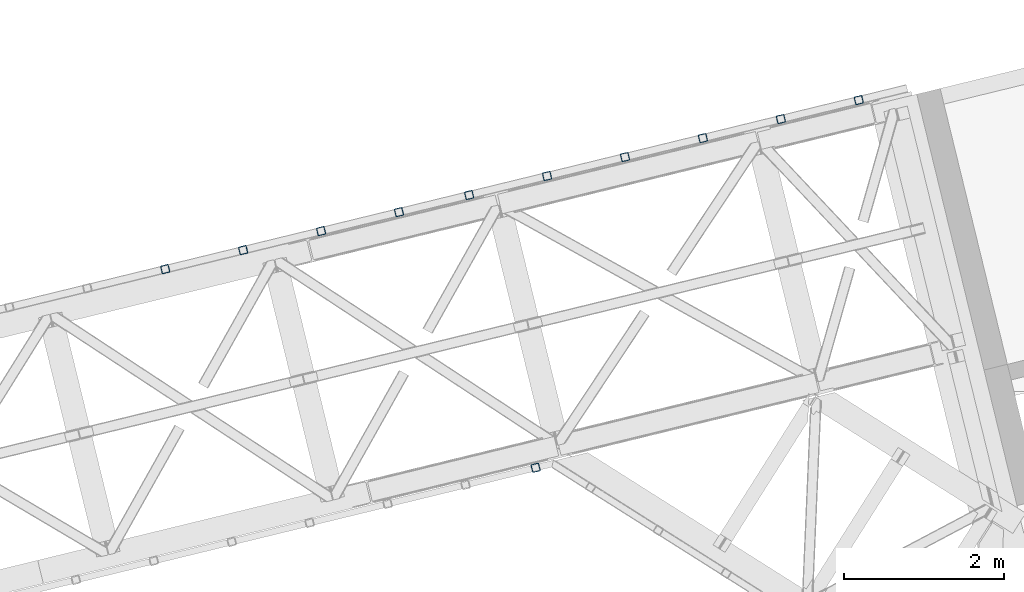
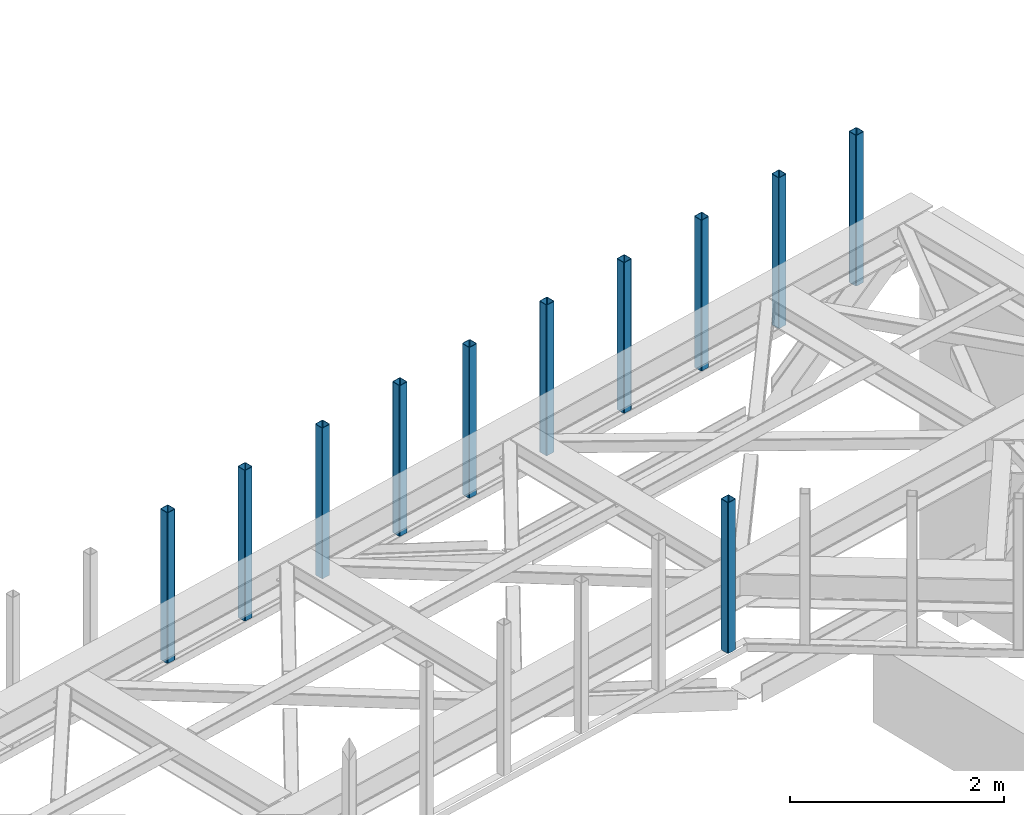
# One storey, part 11 of 66: 11 columns.
"""IFC4 building model written with IfcOpenShell, lengths in millimetres."""

from ifc_helpers import new_model, entity, si_unit, converted_unit, derived_unit, direction, frame, origin, place, context, subcontext, project, spatial, indexed_curve, outline, extrude, type_object, element, save


model = new_model("IFC4")

# Units and contexts
model_context = context("Model", 3, precision=0.01, world=origin(), true_north=direction((6.12303176911189e-17, 1.0)))
plan_context = context("Plan", 3, precision=0.01, world=origin(), true_north=direction((6.12303176911189e-17, 1.0)))
body_context = subcontext(model_context, "Body", "Model", "MODEL_VIEW")
ifc_project = project(units=[si_unit("LENGTHUNIT", "METRE", prefix="MILLI"), si_unit("AREAUNIT", "SQUARE_METRE"), si_unit("VOLUMEUNIT", "CUBIC_METRE"), converted_unit("PLANEANGLEUNIT", "DEGREE", entity("IfcRatioMeasure", 0.0174532925199433), si_unit("PLANEANGLEUNIT", "RADIAN"), dimensions=[0, 0, 0, 0, 0, 0, 0]), si_unit("MASSUNIT", "GRAM", prefix="KILO"), derived_unit("MASSDENSITYUNIT", [(si_unit("MASSUNIT", "GRAM", prefix="KILO"), 1), (si_unit("LENGTHUNIT", "METRE"), -3)]), derived_unit("MOMENTOFINERTIAUNIT", [(si_unit("LENGTHUNIT", "METRE"), 4)]), si_unit("TIMEUNIT", "SECOND"), si_unit("FREQUENCYUNIT", "HERTZ"), si_unit("THERMODYNAMICTEMPERATUREUNIT", "DEGREE_CELSIUS"), derived_unit("THERMALTRANSMITTANCEUNIT", [(si_unit("MASSUNIT", "GRAM", prefix="KILO"), 1), (si_unit("THERMODYNAMICTEMPERATUREUNIT", "KELVIN"), -1), (si_unit("TIMEUNIT", "SECOND"), -3)]), derived_unit("VOLUMETRICFLOWRATEUNIT", [(si_unit("LENGTHUNIT", "METRE"), 3), (si_unit("TIMEUNIT", "SECOND"), -1)]), derived_unit("MASSFLOWRATEUNIT", [(si_unit("MASSUNIT", "GRAM", prefix="KILO"), 1), (si_unit("TIMEUNIT", "SECOND"), -1)]), derived_unit("ROTATIONALFREQUENCYUNIT", [(si_unit("TIMEUNIT", "SECOND"), -1)]), si_unit("ELECTRICCURRENTUNIT", "AMPERE"), si_unit("ELECTRICVOLTAGEUNIT", "VOLT"), si_unit("POWERUNIT", "WATT"), si_unit("FORCEUNIT", "NEWTON", prefix="KILO"), si_unit("ILLUMINANCEUNIT", "LUX"), si_unit("LUMINOUSFLUXUNIT", "LUMEN"), si_unit("LUMINOUSINTENSITYUNIT", "CANDELA"), derived_unit("USERDEFINED", [(si_unit("MASSUNIT", "GRAM", prefix="KILO"), -1), (si_unit("LENGTHUNIT", "METRE"), -2), (si_unit("TIMEUNIT", "SECOND"), 3), (si_unit("LUMINOUSFLUXUNIT", "LUMEN"), 1)]), derived_unit("LINEARVELOCITYUNIT", [(si_unit("LENGTHUNIT", "METRE"), 1), (si_unit("TIMEUNIT", "SECOND"), -1)]), si_unit("PRESSUREUNIT", "PASCAL"), derived_unit("USERDEFINED", [(si_unit("LENGTHUNIT", "METRE"), -2), (si_unit("MASSUNIT", "GRAM", prefix="KILO"), 1), (si_unit("TIMEUNIT", "SECOND"), -2)]), derived_unit("LINEARFORCEUNIT", [(si_unit("MASSUNIT", "GRAM", prefix="KILO"), 1), (si_unit("LENGTHUNIT", "METRE"), 1), (si_unit("TIMEUNIT", "SECOND"), -2), (si_unit("LENGTHUNIT", "METRE"), -1)]), derived_unit("PLANARFORCEUNIT", [(si_unit("MASSUNIT", "GRAM", prefix="KILO"), 1), (si_unit("LENGTHUNIT", "METRE"), 1), (si_unit("TIMEUNIT", "SECOND"), -2), (si_unit("LENGTHUNIT", "METRE"), -2)])], contexts=[model_context, plan_context])

# Site, building, storey
site_placement = place(None, origin())
site = spatial("IfcSite", under=ifc_project, at=site_placement, CompositionType="ELEMENT")
building_placement = place(site_placement, origin())
building = spatial("IfcBuilding", under=site, at=building_placement, CompositionType="ELEMENT")
storey_placement = place(building_placement, frame((0.0, 0.0, 19800.0)))
storey = spatial("IfcBuildingStorey", under=building, at=storey_placement, Name="06", CompositionType="ELEMENT", Elevation=19800.0)

# Columns
column_type_1 = type_object("IfcColumnType", PredefinedType="COLUMN")
placement = place(storey_placement, origin())
element("IfcColumn", 1, at=placement, inside=storey, type_object=column_type_1, ObjectType="Steel Column", PredefinedType="COLUMN", context=body_context, shape_type="SweptSolid", body=[
    extrude(outline(indexed_curve([(29.4768951153438, -56.8428769007969), (33.3787015556646, -56.8428769007969), (36.9835006656957, -55.3497202197868), (39.742494458526, -52.5907264269608), (41.235651139533, -48.9859273169217), (56.8428769007998, 29.476895115338), (56.8428769007996, 33.3787015556615), (55.3497202197897, 36.9835006656988), (52.5907264269624, 39.7424944585244), (48.9859273169288, 41.2356511395317), (-29.476895115342, 56.8428769008008), (-33.3787015556628, 56.8428769008008), (-36.9835006657015, 55.3497202197943), (-39.7424944585166, 52.5907264269612), (-41.2356511395312, 48.9859273169256), (-56.8428769007996, -29.4768951153381), (-56.84287690079, -33.3787015556612), (-55.3497202197955, -36.9835006656913), (-52.5907264269606, -39.7424944585204), (-48.985927316927, -41.2356511395278), (29.4768951153438, -56.8428769007969)], self_intersect=False), holes=[indexed_curve([(-43.1065493048248, -37.3071763475937), (-46.7113484148532, -35.8140196665887), (-49.4703422076904, -33.0550258737586), (-50.9634988886897, -29.4502267637262), (-50.9634988886947, -25.5484203234053), (-37.3071763475804, 43.106549304824), (-35.8140196665827, 46.7113484148579), (-33.0550258737537, 49.470342207694), (-29.4502267637163, 50.9634988886964), (-25.5484203233976, 50.9634988887022), (43.1065493048361, 37.3071763475885), (46.7113484148689, 35.8140196665814), (49.4703422076964, 33.0550258737511), (50.963498888715, 29.450226763724), (50.9634988887109, 25.5484203233977), (37.3071763475966, -43.1065493048315), (35.8140196665955, -46.7113484148734), (33.0550258737621, -49.4703422076932), (29.4502267637325, -50.963498888704), (25.5484203234073, -50.9634988887019), (-43.1065493048248, -37.3071763475937)], self_intersect=False)]), frame((-1656.48, 20594.42, 3378.0), z_axis=(0.0, 0.0, 1.0), x_axis=(0.906681479027433, 0.421815949898326, 0.0)), (0.0, 0.0, 1.0), 1720.00000000001),
])
column_type_2 = type_object("IfcColumnType", PredefinedType="COLUMN")
element("IfcColumn", 2, at=placement, inside=storey, type_object=column_type_2, ObjectType="Steel Column", PredefinedType="COLUMN", context=body_context, shape_type="SweptSolid", body=[
    extrude(outline(indexed_curve([(29.4768951153443, -56.8428769007955), (33.3787015556653, -56.8428769007955), (36.983500665704, -55.3497202197888), (39.7424944585282, -52.5907264269551), (41.2356511395332, -48.9859273169199), (56.8428769007977, 29.4768951153402), (56.8428769007972, 33.3787015556638), (55.3497202197953, 36.9835006656973), (52.5907264269598, 39.7424944585266), (48.9859273169262, 41.2356511395338), (-29.4768951153449, 56.8428769008005), (-33.3787015556659, 56.8428769008005), (-36.9835006656967, 55.3497202197902), (-39.7424944585288, 52.5907264269602), (-41.2356511395338, 48.985927316925), (-56.8428769008002, -29.4768951153391), (-56.8428769007996, -33.3787015556627), (-55.349720219788, -36.9835006656959), (-52.5907264269604, -39.7424944585215), (-48.9859273169273, -41.2356511395285), (29.4768951153443, -56.8428769007955)], self_intersect=False), holes=[indexed_curve([(-43.1065493048252, -37.3071763475943), (-46.7113484148636, -35.8140196665896), (-49.4703422076951, -33.0550258737479), (-50.9634988886977, -29.4502267637236), (-50.9634988887035, -25.5484203234023), (-37.3071763475993, 43.1065493048311), (-35.814019666589, 46.7113484148687), (-33.0550258737723, 49.4703422076915), (-29.4502267637273, 50.9634988887), (-25.5484203234006, 50.9634988887021), (43.1065493048173, 37.307176347598), (46.7113484148541, 35.8140196665988), (49.4703422076856, 33.0550258737571), (50.9634988886948, 29.450226763725), (50.9634988887006, 25.5484203234037), (37.3071763475946, -43.1065493048337), (35.8140196665904, -46.7113484148645), (33.0550258737537, -49.4703422076876), (29.4502267637152, -50.9634988886992), (25.5484203233981, -50.963498888701), (-43.1065493048252, -37.3071763475943)], self_intersect=False)]), frame((-2628.03, 20357.59, 3378.0), z_axis=(0.0, 0.0, 1.0), x_axis=(0.906681479027445, 0.4218159498983, 0.0)), (0.0, 0.0, 1.0), 1720.00000000001),
])
column_type_3 = type_object("IfcColumnType", PredefinedType="COLUMN")
element("IfcColumn", 3, at=placement, inside=storey, type_object=column_type_3, ObjectType="Steel Column", PredefinedType="COLUMN", context=body_context, shape_type="SweptSolid", body=[
    extrude(outline(indexed_curve([(29.4768951152834, -56.842876900833), (33.3787015556062, -56.842876900833), (36.9835006656294, -55.3497202198268), (39.7424944584721, -52.5907264270032), (41.2356511394807, -48.9859273169695), (56.8428769008256, 29.4768951152791), (56.8428769008295, 33.3787015556025), (55.3497202198136, 36.9835006656409), (52.5907264269984, 39.7424944584695), (48.9859273169645, 41.2356511394765), (-29.4768951152816, 56.8428769008226), (-33.3787015556026, 56.8428769008265), (-36.983500665652, 55.349720219823), (-39.7424944584698, 52.5907264269926), (-41.2356511394877, 48.9859273169583), (-56.8428769008312, -29.476895115286), (-56.8428769008272, -33.3787015556131), (-55.3497202198363, -36.9835006656447), (-52.5907264269944, -39.7424944584762), (-48.9859273169628, -41.2356511394868), (29.4768951152834, -56.842876900833)], self_intersect=False), holes=[indexed_curve([(-43.1065493048641, -37.3071763475551), (-46.711348414901, -35.8140196665468), (-49.470342207726, -33.0550258737136), (-50.9634988887297, -29.450226763676), (-50.9634988887227, -25.5484203233588), (-37.3071763475573, 43.1065493048645), (-35.8140196665383, 46.7113484148934), (-33.0550258737162, 49.4703422077266), (-29.4502267636774, 50.9634988887255), (-25.5484203233506, 50.9634988887237), (43.1065493048536, 37.3071763475504), (46.711348414896, 35.814019666549), (49.4703422077232, 33.0550258737101), (50.9634988887331, 29.4502267636744), (50.963498888725, 25.5484203233482), (37.3071763475433, -43.1065493048675), (35.8140196665392, -46.7113484149082), (33.0550258737026, -49.470342207725), (29.4502267636626, -50.9634988887329), (25.5484203233455, -50.9634988887308), (-43.1065493048641, -37.3071763475551)], self_intersect=False)]), frame((-3599.58, 20120.77, 3378.0), z_axis=(0.0, 0.0, 1.0), x_axis=(0.90668147902702, 0.421815949899212, 0.0)), (0.0, 0.0, 1.0), 1720.00000000001),
])
column_type_4 = type_object("IfcColumnType", PredefinedType="COLUMN")
element("IfcColumn", 4, at=placement, inside=storey, type_object=column_type_4, ObjectType="Steel Column", PredefinedType="COLUMN", context=body_context, shape_type="SweptSolid", body=[
    extrude(outline(indexed_curve([(29.4768951153332, -56.8428769007999), (33.3787015556542, -56.8428769007999), (36.9835006657021, -55.3497202197927), (39.7424944585171, -52.5907264269596), (41.23565113953, -48.985927316928), (56.8428769007959, 29.4768951153363), (56.8428769007862, 33.3787015556594), (55.3497202197934, 36.9835006656934), (52.5907264269487, 39.7424944585222), (48.9859273169151, 41.2356511395294), (-29.4768951153389, 56.842876900793), (-33.3787015556599, 56.842876900793), (-36.9835006656907, 55.3497202197826), (-39.7424944585301, 52.590726426956), (-41.2356511395278, 48.9859273169174), (-56.8428769007942, -29.4768951153466), (-56.8428769008015, -33.3787015556666), (-55.349720219782, -36.9835006657035), (-52.5907264269544, -39.7424944585291), (-48.9859273169212, -41.2356511395361), (29.4768951153332, -56.8428769007999)], self_intersect=False), holes=[indexed_curve([(-43.1065493048265, -37.3071763475985), (-46.7113484148607, -35.8140196666053), (-49.4703422076881, -33.0550258737702), (-50.9634988886994, -29.4502267637324), (-50.963498888697, -25.5484203234101), (-37.3071763475863, 43.1065493048155), (-35.8140196665868, 46.7113484148581), (-33.0550258737512, 49.4703422076817), (-29.4502267637208, 50.9634988886922), (-25.5484203234024, 50.9634988886982), (43.1065493048304, 37.3071763475823), (46.7113484148666, 35.8140196665834), (49.4703422076925, 33.0550258737539), (50.9634988887013, 29.4502267637172), (50.9634988886992, 25.5484203233995), (37.307176347595, -43.1065493048339), (35.8140196665866, -46.7113484148675), (33.05502587376, -49.4703422077049), (29.4502267637291, -50.9634988887104), (25.5484203234041, -50.9634988887086), (-43.1065493048265, -37.3071763475985)], self_intersect=False)]), frame((-4571.13, 19883.94, 3378.0), z_axis=(0.0, 0.0, 1.0), x_axis=(0.906681479027445, 0.4218159498983, 0.0)), (0.0, 0.0, 1.0), 1720.00000000001),
])
column_type_5 = type_object("IfcColumnType", PredefinedType="COLUMN")
element("IfcColumn", 5, at=placement, inside=storey, type_object=column_type_5, ObjectType="Steel Column", PredefinedType="COLUMN", context=body_context, shape_type="SweptSolid", body=[
    extrude(outline(indexed_curve([(29.4768951153379, -56.8428769007925), (33.3787015556589, -56.8428769007925), (36.9835006656981, -55.349720219786), (39.7424944585296, -52.5907264269558), (41.2356511395273, -48.9859273169171), (56.8428769007914, 29.4768951153432), (56.842876900801, 33.3787015556669), (55.3497202197894, 36.9835006657001), (52.5907264269544, 39.7424944585291), (48.9859273169203, 41.2356511395366), (-29.4768951153342, 56.8428769008003), (-33.3787015556542, 56.8428769007999), (-36.9835006656934, 55.3497202197934), (-39.7424944585171, 52.5907264269595), (-41.2356511395305, 48.9859273169282), (-56.8428769007964, -29.476895115336), (-56.8428769007885, -33.3787015556631), (-55.3497202197847, -36.9835006656927), (-52.5907264269497, -39.7424944585217), (-48.9859273169156, -41.2356511395292), (29.4768951153379, -56.8428769007925)], self_intersect=False), holes=[indexed_curve([(-43.1065493048293, -37.3071763475876), (-46.7113484148548, -35.8140196665746), (-49.4703422076866, -33.0550258737566), (-50.9634988886944, -29.4502267637204), (-50.9634988886905, -25.5484203233988), (-37.3071763475803, 43.106549304827), (-35.8140196665784, 46.7113484148542), (-33.0550258737519, 49.4703422076916), (-29.4502267637225, 50.9634988887026), (-25.5484203234065, 50.9634988887049), (43.1065493048387, 37.3071763475976), (46.7113484148736, 35.8140196665945), (49.4703422077027, 33.0550258737682), (50.9634988887155, 29.4502267637297), (50.9634988887136, 25.5484203234072), (37.3071763475997, -43.1065493048265), (35.8140196665941, -46.7113484148615), (33.0550258737577, -49.4703422076895), (29.4502267637378, -50.9634988886954), (25.5484203234111, -50.9634988886975), (-43.1065493048293, -37.3071763475876)], self_intersect=False)]), frame((-5542.69, 19647.12, 3378.0), z_axis=(0.0, 0.0, 1.0), x_axis=(0.906681479027445, 0.4218159498983, 0.0)), (0.0, 0.0, 1.0), 1720.00000000001),
])
column_type_6 = type_object("IfcColumnType", PredefinedType="COLUMN")
element("IfcColumn", 6, at=placement, inside=storey, type_object=column_type_6, ObjectType="Steel Column", PredefinedType="COLUMN", context=body_context, shape_type="SweptSolid", body=[
    extrude(outline(indexed_curve([(29.476895115345, -56.8428769008029), (33.378701555666, -56.8428769008029), (36.9835006656885, -55.3497202197912), (39.7424944585289, -52.590726426965), (41.2356511395335, -48.9859273169296), (56.8428769008003, 29.4768951153342), (56.8428769007993, 33.3787015556581), (55.3497202197789, 36.983500665693), (52.5907264269614, 39.7424944585186), (48.9859273169273, 41.2356511395261), (-29.4768951153437, 56.8428769007928), (-33.3787015556656, 56.8428769007908), (-36.983500665696, 55.3497202197827), (-39.7424944585276, 52.5907264269525), (-41.2356511395409, 48.9859273169187), (-56.8428769008078, -29.4768951153451), (-56.842876900798, -33.3787015556682), (-55.3497202197864, -36.9835006657039), (-52.5907264269601, -39.7424944585312), (-48.9859273169261, -41.2356511395363), (29.476895115345, -56.8428769008029)], self_intersect=False), holes=[indexed_curve([(-43.106549304823, -37.3071763476025), (-46.71134841486, -35.814019666596), (-49.4703422076915, -33.0550258737543), (-50.9634988886951, -29.4502267637296), (-50.9634988887009, -25.5484203234083), (-37.3071763475967, 43.1065493048251), (-35.8140196665883, 46.7113484148588), (-33.0550258737691, 49.4703422076828), (-29.4502267637233, 50.9634988886958), (-25.5484203233984, 50.9634988886939), (43.1065493048204, 37.3071763475917), (46.7113484148563, 35.8140196665906), (49.4703422076896, 33.0550258737528), (50.9634988886973, 29.450226763719), (50.9634988887041, 25.5484203233997), (37.3071763475981, -43.1065493048377), (35.8140196665925, -46.7113484148727), (33.0550258737568, -49.4703422076938), (29.4502267637188, -50.9634988887056), (25.5484203234007, -50.963498888707), (-43.106549304823, -37.3071763476025)], self_intersect=False)]), frame((-6514.24, 19410.29, 3378.0), z_axis=(0.0, 0.0, 1.0), x_axis=(0.906681479027445, 0.4218159498983, 0.0)), (0.0, 0.0, 1.0), 1720.00000000001),
])
column_type_7 = type_object("IfcColumnType", PredefinedType="COLUMN")
element("IfcColumn", 7, at=placement, inside=storey, type_object=column_type_7, ObjectType="Steel Column", PredefinedType="COLUMN", context=body_context, shape_type="SweptSolid", body=[
    extrude(outline(indexed_curve([(29.4768951153447, -56.8428769007933), (33.3787015556657, -56.8428769007933), (36.9835006657039, -55.3497202197863), (39.7424944585189, -52.5907264269532), (41.2356511395322, -48.9859273169194), (56.8428769007991, 29.4768951153444), (56.8428769007903, 33.3787015556695), (55.3497202197952, 36.9835006656998), (52.5907264269602, 39.7424944585288), (48.9859273169261, 41.2356511395363), (-29.4768951153362, 56.8428769008012), (-33.3787015556581, 56.8428769007993), (-36.9835006656963, 55.3497202197924), (-39.7424944585289, 52.5907264269626), (-41.2356511395246, 48.9859273169254), (-56.8428769007915, -29.4768951153384), (-56.8428769007983, -33.3787015556586), (-55.3497202197876, -36.9835006656938), (-52.5907264269526, -39.7424944585228), (-48.9859273169186, -41.2356511395278), (29.4768951153447, -56.8428769007933)], self_intersect=False), holes=[indexed_curve([(-43.106549304833, -37.3071763475907), (-46.7113484148615, -35.8140196665787), (-49.4703422076866, -33.0550258737542), (-50.963498888706, -29.4502267637222), (-50.9634988887031, -25.5484203234001), (-37.307176347591, 43.1065493048296), (-35.8140196665906, 46.7113484148718), (-33.0550258737549, 49.4703422076953), (-29.4502267637333, 50.9634988887052), (-25.5484203234075, 50.9634988887077), (43.1065493048279, 37.3071763476002), (46.7113484148602, 35.8140196665888), (49.470342207697, 33.0550258737661), (50.9634988886961, 29.4502267637292), (50.9634988887019, 25.5484203234078), (37.3071763475908, -43.10654930482), (35.8140196665883, -46.7113484148612), (33.055025873754, -49.4703422076949), (29.4502267637253, -50.9634988886967), (25.5484203234082, -50.9634988886985), (-43.106549304833, -37.3071763475907)], self_intersect=False)]), frame((-7388.63, 19197.15, 3378.0), z_axis=(0.0, 0.0, 1.0), x_axis=(0.906681479027445, 0.4218159498983, 0.0)), (0.0, 0.0, 1.0), 1720.00000000001),
])
column_type_8 = type_object("IfcColumnType", PredefinedType="COLUMN")
element("IfcColumn", 8, at=placement, inside=storey, type_object=column_type_8, ObjectType="Steel Column", PredefinedType="COLUMN", context=body_context, shape_type="SweptSolid", body=[
    extrude(outline(indexed_curve([(29.4768951153362, -56.8428769008012), (33.3787015556572, -56.8428769008012), (36.9835006656963, -55.3497202197924), (39.7424944585279, -52.5907264269646), (41.2356511395247, -48.9859273169279), (56.8428769007906, 29.4768951153364), (56.8428769007983, 33.3787015556586), (55.3497202197867, 36.9835006656918), (52.5907264269526, 39.7424944585228), (48.9859273169186, 41.2356511395278), (-29.4768951153359, 56.8428769007916), (-33.3787015556578, 56.8428769007896), (-36.9835006657048, 55.3497202197844), (-39.7424944585198, 52.5907264269512), (-41.2356511395331, 48.9859273169175), (-56.8428769008, -29.4768951153463), (-56.8428769007903, -33.3787015556695), (-55.3497202197961, -36.9835006657017), (-52.5907264269523, -39.7424944585324), (-48.9859273169183, -41.2356511395375), (29.4768951153362, -56.8428769008012)], self_intersect=False), holes=[indexed_curve([(-43.1065493048328, -37.3071763476003), (-46.7113484148662, -35.8140196665836), (-49.4703422076883, -33.0550258737654), (-50.9634988886978, -29.4502267637355), (-50.963498888694, -25.5484203234115), (-37.3071763475838, 43.1065493048144), (-35.8140196665864, 46.7113484148603), (-33.0550258737616, 49.4703422076913), (-29.450226763733, 50.9634988886955), (-25.5484203234081, 50.9634988886961), (43.1065493048282, 37.3071763475905), (46.7113484148701, 35.8140196665818), (49.4703422076932, 33.0550258737631), (50.9634988887051, 29.4502267637202), (50.9634988887031, 25.5484203234001), (37.307176347591, -43.1065493048296), (35.8140196665894, -46.7113484148641), (33.0550258737542, -49.4703422077022), (29.4502267637256, -50.9634988887064), (25.5484203234085, -50.9634988887082), (-43.1065493048328, -37.3071763476003)], self_intersect=False)]), frame((-8360.19, 18960.32, 3378.0), z_axis=(0.0, 0.0, 1.0), x_axis=(0.906681479027445, 0.4218159498983, 0.0)), (0.0, 0.0, 1.0), 1720.00000000001),
])
column_type_9 = type_object("IfcColumnType", PredefinedType="COLUMN")
element("IfcColumn", 9, at=placement, inside=storey, type_object=column_type_9, ObjectType="Steel Column", PredefinedType="COLUMN", context=body_context, shape_type="SweptSolid", body=[
    extrude(outline(indexed_curve([(29.4768951153467, -56.8428769007942), (33.3787015556676, -56.8428769007942), (36.9835006656902, -55.3497202197824), (39.7424944585209, -52.5907264269541), (41.2356511395352, -48.9859273169208), (56.842876900801, 29.4768951153434), (56.8428769007922, 33.3787015556685), (55.3497202197806, 36.9835006657018), (52.5907264269631, 39.7424944585298), (48.985927316929, 41.2356511395349), (-29.476895115343, 56.842876900802), (-33.3787015556639, 56.8428769007996), (-36.9835006656943, 55.3497202197915), (-39.7424944585181, 52.59072642696), (-41.2356511395314, 48.9859273169262), (-56.8428769007964, -29.476895115336), (-56.8428769007876, -33.3787015556612), (-55.3497202197856, -36.9835006656947), (-52.5907264269594, -39.742494458522), (-48.9859273169244, -41.2356511395275), (29.4768951153467, -56.8428769007942)], self_intersect=False), holes=[indexed_curve([(-43.1065493048223, -37.3071763475933), (-46.7113484148514, -35.8140196665905), (-49.4703422076943, -33.0550258737578), (-50.9634988886962, -29.4502267637267), (-50.9634988886924, -25.5484203234027), (-37.3071763475882, 43.1065493048307), (-35.8140196665797, 46.7113484148643), (-33.0550258737519, 49.4703422076916), (-29.4502267637139, 50.9634988887033), (-25.5484203233977, 50.9634988887032), (43.106549304829, 37.3071763475973), (46.7113484148657, 35.8140196665981), (49.4703422076903, 33.0550258737621), (50.9634988887068, 29.450226763729), (50.9634988887048, 25.5484203234089), (37.3071763475988, -43.1065493048285), (35.8140196665911, -46.7113484148553), (33.0550258737654, -49.4703422076883), (29.4502267637273, -50.9634988887), (25.5484203234014, -50.9634988886977), (-43.1065493048223, -37.3071763475933)], self_intersect=False)]), frame((-9331.74, 18723.49, 3378.0), z_axis=(0.0, 0.0, 1.0), x_axis=(0.906681479027445, 0.4218159498983, 0.0)), (0.0, 0.0, 1.0), 1720.00000000001),
])
column_type_10 = type_object("IfcColumnType", PredefinedType="COLUMN")
element("IfcColumn", 10, at=placement, inside=storey, type_object=column_type_10, ObjectType="Steel Column", PredefinedType="COLUMN", context=body_context, shape_type="SweptSolid", body=[
    extrude(outline(indexed_curve([(29.4768951153351, -56.8428769007984), (33.3787015556561, -56.8428769007984), (36.9835006656943, -55.3497202197915), (39.7424944585259, -52.5907264269612), (41.2356511395227, -48.9859273169245), (56.8428769007886, 29.4768951153397), (56.8428769007982, 33.378701555661), (55.3497202197866, 36.9835006656942), (52.5907264269506, 39.7424944585237), (48.9859273169165, 41.2356511395312), (-29.476895115337, 56.8428769007944), (-33.3787015556589, 56.8428769007925), (-36.9835006656971, 55.3497202197856), (-39.7424944585218, 52.5907264269546), (-41.2356511395342, 48.9859273169203), (-56.8428769008001, -29.4768951153439), (-56.8428769007913, -33.3787015556666), (-55.3497202197894, -36.9835006657001), (-52.5907264269534, -39.7424944585296), (-48.9859273169203, -41.2356511395342), (29.4768951153351, -56.8428769007984)], self_intersect=False), holes=[indexed_curve([(-43.1065493048328, -37.3071763475979), (-46.7113484148583, -35.8140196665873), (-49.4703422076902, -33.0550258737645), (-50.9634988886981, -29.4502267637282), (-50.963498888695, -25.548420323411), (-37.3071763475848, 43.1065493048148), (-35.8140196665802, 46.7113484148478), (-33.0550258737556, 49.4703422076837), (-29.4502267637252, 50.9634988886943), (-25.5484203234092, 50.963498888699), (43.1065493048351, 37.3071763475873), (46.7113484148681, 35.8140196665827), (49.4703422077001, 33.0550258737599), (50.9634988887118, 29.4502267637219), (50.96349888871, 25.5484203233969), (37.3071763475969, -43.10654930483), (35.8140196665877, -46.7113484148728), (33.0550258737542, -49.4703422077021), (29.4502267637324, -50.9634988887096), (25.5484203234084, -50.9634988887058), (-43.1065493048328, -37.3071763475979)], self_intersect=False)]), frame((-10303.29, 18486.67, 3378.0), z_axis=(0.0, 0.0, 1.0), x_axis=(0.906681479027445, 0.4218159498983, 0.0)), (0.0, 0.0, 1.0), 1720.00000000001),
])
column_type_11 = type_object("IfcColumnType", PredefinedType="COLUMN")
element("IfcColumn", 11, at=placement, inside=storey, type_object=column_type_11, ObjectType="Steel Column", PredefinedType="COLUMN", context=body_context, shape_type="SweptSolid", body=[
    extrude(outline(indexed_curve([(29.4768951153175, -56.8428769007893), (33.3787015556517, -56.8428769007893), (36.9835006656797, -55.3497202197804), (39.742494458509, -52.5907264269499), (41.2356511395092, -48.9859273169124), (56.8428769008095, 29.4768951153402), (56.8428769008059, 33.3787015556642), (55.3497202198135, 36.9835006656941), (52.5907264269757, 39.7424944585232), (48.9859273169434, 41.2356511395293), (-29.4768951153155, 56.8428769007884), (-33.3787015556488, 56.8428769007903), (-36.9835006656681, 55.3497202197797), (-39.7424944585071, 52.5907264269514), (-41.2356511395063, 48.9859273169134), (-56.8428769008067, -29.4768951153392), (-56.842876900803, -33.3787015556631), (-55.3497202198106, -36.983500665693), (-52.5907264269815, -39.7424944585204), (-48.9859273169405, -41.2356511395282), (29.4768951153175, -56.8428769007893)], self_intersect=False), holes=[indexed_curve([(-43.1065493048481, -37.307176347587), (-46.7113484148773, -35.8140196665895), (-49.4703422077104, -33.0550258737554), (-50.9634988887155, -29.450226763722), (-50.963498888721, -25.5484203233995), (-37.3071763475943, 43.10654930483), (-35.8140196665766, 46.7113484148641), (-33.0550258737414, 49.4703422076918), (-29.4502267637171, 50.9634988886953), (-25.5484203233908, 50.963498888699), (43.1065493048441, 37.3071763475912), (46.7113484148705, 35.8140196665903), (49.4703422077045, 33.0550258737558), (50.9634988887037, 29.4502267637275), (50.9634988887073, 25.548420323406), (37.3071763475824, -43.1065493048196), (35.8140196665705, -46.7113484148492), (33.0550258737373, -49.4703422076803), (29.4502267637121, -50.9634988886881), (25.5484203233868, -50.9634988886923), (-43.1065493048481, -37.307176347587)], self_intersect=False)]), frame((-5685.11, 16009.75, 3378.0), z_axis=(0.0, 0.0, 1.0), x_axis=(-0.904974271849281, -0.425466293953896, 0.0)), (0.0, 0.0, 1.0), 1719.99999999989),
])

save(model, "model.ifc")
